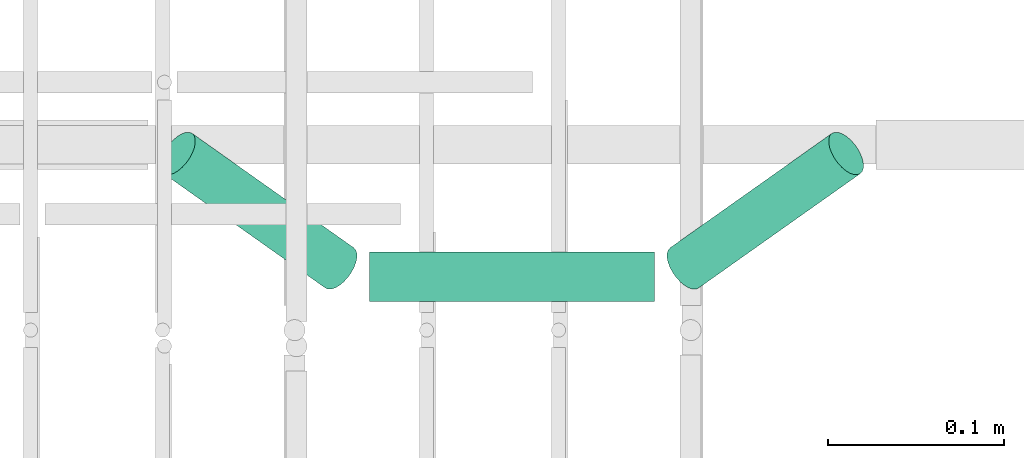
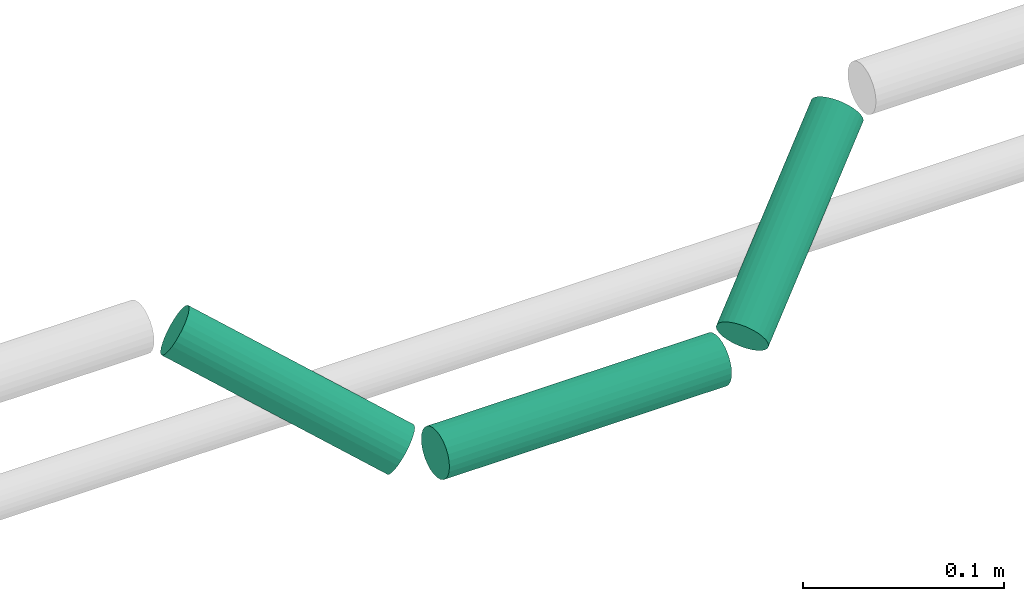
# One storey, part 187 of 331: 3 flow segments.
"""IFC2X3 building model written with IfcOpenShell, lengths in millimetres."""

from ifc_helpers import new_model, entity, si_unit, converted_unit, derived_unit, direction, frame, frame_2d, origin, origin_2d_with_axis, place, context, subcontext, project, spatial, circle, extrude, type_object, element, save


model = new_model("IFC2X3")

# Units and contexts
model_context = context("Model", 3, precision=0.01, world=origin(), true_north=direction((6.12303176911189e-17, 1.0)))
body_context = subcontext(model_context, "Body", "Model", "MODEL_VIEW")
ifc_project = project(units=[si_unit("LENGTHUNIT", "METRE", prefix="MILLI"), si_unit("AREAUNIT", "SQUARE_METRE"), si_unit("VOLUMEUNIT", "CUBIC_METRE"), converted_unit("PLANEANGLEUNIT", "DEGREE", entity("IfcRatioMeasure", 0.0174532925199433), si_unit("PLANEANGLEUNIT", "RADIAN"), dimensions=[0, 0, 0, 0, 0, 0, 0]), si_unit("MASSUNIT", "GRAM", prefix="KILO"), derived_unit("MASSDENSITYUNIT", [(si_unit("MASSUNIT", "GRAM", prefix="KILO"), 1), (si_unit("LENGTHUNIT", "METRE"), -3)]), derived_unit("MOMENTOFINERTIAUNIT", [(si_unit("LENGTHUNIT", "METRE"), 4)]), si_unit("TIMEUNIT", "SECOND"), si_unit("FREQUENCYUNIT", "HERTZ"), si_unit("THERMODYNAMICTEMPERATUREUNIT", "DEGREE_CELSIUS"), derived_unit("THERMALTRANSMITTANCEUNIT", [(si_unit("MASSUNIT", "GRAM", prefix="KILO"), 1), (si_unit("THERMODYNAMICTEMPERATUREUNIT", "KELVIN"), -1), (si_unit("TIMEUNIT", "SECOND"), -3)]), derived_unit("VOLUMETRICFLOWRATEUNIT", [(si_unit("LENGTHUNIT", "METRE"), 3), (si_unit("TIMEUNIT", "SECOND"), -1)]), derived_unit("MASSFLOWRATEUNIT", [(si_unit("MASSUNIT", "GRAM", prefix="KILO"), 1), (si_unit("TIMEUNIT", "SECOND"), -1)]), derived_unit("ROTATIONALFREQUENCYUNIT", [(si_unit("TIMEUNIT", "SECOND"), -1)]), si_unit("ELECTRICCURRENTUNIT", "AMPERE"), si_unit("ELECTRICVOLTAGEUNIT", "VOLT"), si_unit("POWERUNIT", "WATT"), si_unit("FORCEUNIT", "NEWTON", prefix="KILO"), si_unit("ILLUMINANCEUNIT", "LUX"), si_unit("LUMINOUSFLUXUNIT", "LUMEN"), si_unit("LUMINOUSINTENSITYUNIT", "CANDELA"), derived_unit("USERDEFINED", [(si_unit("MASSUNIT", "GRAM", prefix="KILO"), -1), (si_unit("LENGTHUNIT", "METRE"), -2), (si_unit("TIMEUNIT", "SECOND"), 3), (si_unit("LUMINOUSFLUXUNIT", "LUMEN"), 1)]), derived_unit("LINEARVELOCITYUNIT", [(si_unit("LENGTHUNIT", "METRE"), 1), (si_unit("TIMEUNIT", "SECOND"), -1)]), si_unit("PRESSUREUNIT", "PASCAL"), derived_unit("USERDEFINED", [(si_unit("LENGTHUNIT", "METRE"), -2), (si_unit("MASSUNIT", "GRAM", prefix="KILO"), 1), (si_unit("TIMEUNIT", "SECOND"), -2)]), derived_unit("LINEARFORCEUNIT", [(si_unit("MASSUNIT", "GRAM", prefix="KILO"), 1), (si_unit("LENGTHUNIT", "METRE"), 1), (si_unit("TIMEUNIT", "SECOND"), -2), (si_unit("LENGTHUNIT", "METRE"), -1)]), derived_unit("PLANARFORCEUNIT", [(si_unit("MASSUNIT", "GRAM", prefix="KILO"), 1), (si_unit("LENGTHUNIT", "METRE"), 1), (si_unit("TIMEUNIT", "SECOND"), -2), (si_unit("LENGTHUNIT", "METRE"), -2)])], contexts=[model_context])

# Site, building, storey
site_placement = place(None, frame((0.0, -0.00077364408347762, 0.0)))
site = spatial("IfcSite", under=ifc_project, at=site_placement, CompositionType="ELEMENT")
building_placement = place(site_placement, origin())
building = spatial("IfcBuilding", under=site, at=building_placement, CompositionType="ELEMENT")
storey_placement = place(building_placement, origin())
storey = spatial("IfcBuildingStorey", under=building, at=storey_placement, CompositionType="ELEMENT", Elevation=0.0)

# Flow segments
pipe_segment_type = type_object("IfcPipeSegmentType", PredefinedType="NOTDEFINED")
flow_segment_1_placement = place(building_placement, frame((43662.6731803143, 8104.92098945675, 2684.40472776408)))
element("IfcFlowSegment", 1, at=flow_segment_1_placement, inside=storey, type_object=pipe_segment_type, context=body_context, shape_type="SweptSolid", body=[
    extrude(circle(Radius=14.0, at=origin_2d_with_axis()), frame((0.0, 15.595272235916, 15.5952722359165), z_axis=(1.0, 0.0, 0.0), x_axis=(0.0, 1.0, 0.0)), (0.0, 0.0, 1.0), 161.798826034393),
])
flow_segment_2_placement = place(building_placement, frame((43542.2858347104, 8111.83662147588, 2691.28318658167)))
element("IfcFlowSegment", 2, at=flow_segment_2_placement, inside=storey, type_object=pipe_segment_type, context=body_context, shape_type="SweptSolid", body=[
    extrude(circle(Radius=14.0, at=frame_2d((8.8397375657932e-13, 3.12823902962938e-13), x_axis=(1.0, 0.0))), frame((103.318479392182, 13.6811964986339, 13.7183697001943), z_axis=(-0.706886621169675, 0.500155628185151, 0.500155628185905), x_axis=(-0.577589911755143, -0.816327075282136, 0.0)), (0.0, 0.0, 1.0), 129.953326071689),
])
flow_segment_3_placement = place(building_placement, frame((43830.0846607448, 8111.83662147589, 2691.28318658166)))
element("IfcFlowSegment", 3, at=flow_segment_3_placement, inside=storey, type_object=pipe_segment_type, context=body_context, shape_type="SweptSolid", body=[
    extrude(circle(Radius=14.0, at=frame_2d((-3.00556004889206e-29, -9.37693124953544e-13), x_axis=(1.0, 0.0))), frame((11.4562118156145, 13.6811964986285, 13.7183697001965), z_axis=(0.706886621169621, 0.500155628185318, 0.500155628185814), x_axis=(-0.577589911755301, 0.816327075282024, 0.0)), (0.0, 0.0, 1.0), 129.953326071687),
])

save(model, "model.ifc")
